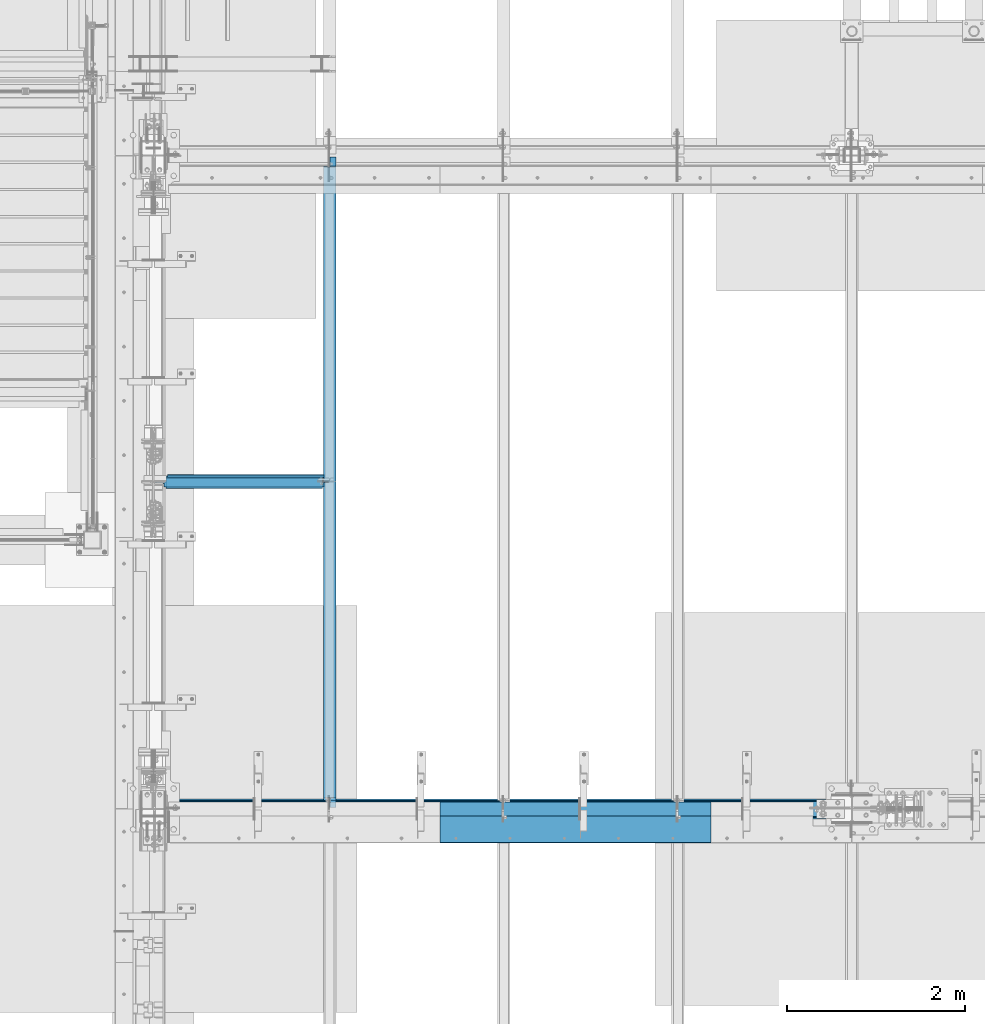
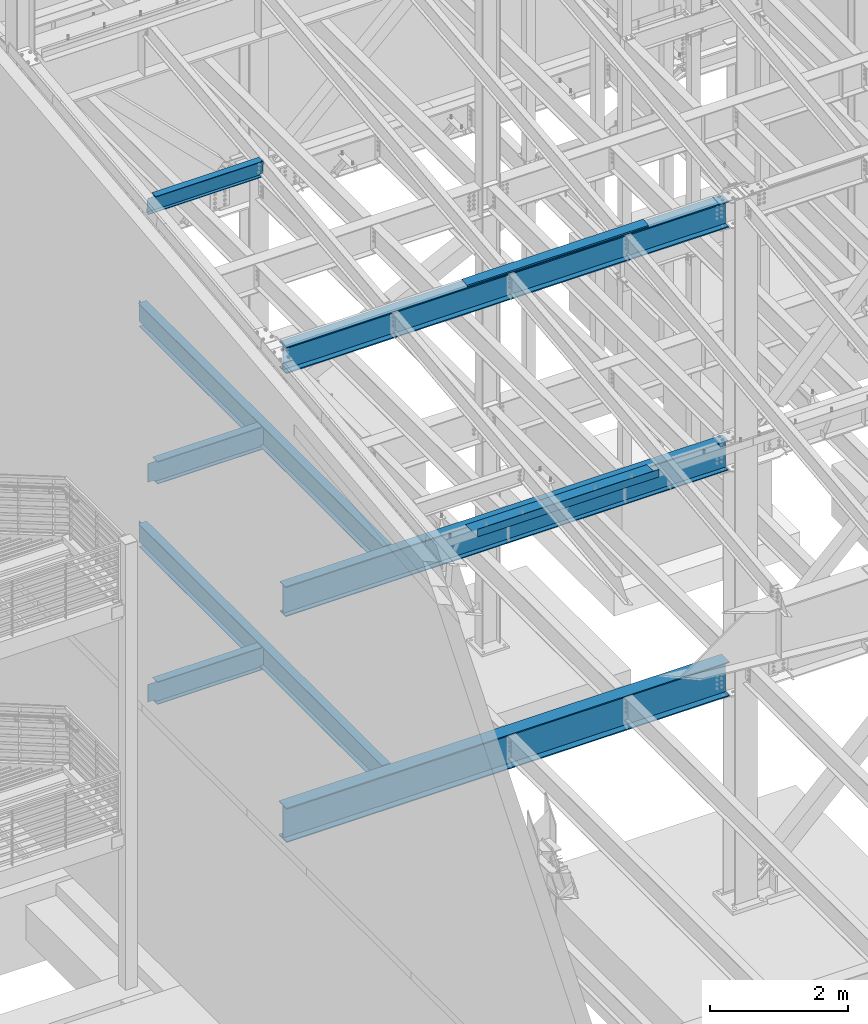
# One storey, part 731 of 1179: 10 beams, 8 elements without a shape of their own.
"""IFC2X3 building model written with IfcOpenShell, lengths in millimetres."""

from ifc_helpers import new_model, si_unit, frame, origin_with_axes, place, context, subcontext, project, spatial, faceted_brep, material, type_object, element, aggregate, save


model = new_model("IFC2X3")

# Units and contexts
model_context = context("Model", 3, precision=1e-05, world=origin_with_axes())
body_context = subcontext(model_context, "Body", "Model", "MODEL_VIEW")
ifc_project = project(units=[si_unit("LENGTHUNIT", "METRE", prefix="MILLI"), si_unit("AREAUNIT", "SQUARE_METRE"), si_unit("VOLUMEUNIT", "CUBIC_METRE"), si_unit("MASSUNIT", "GRAM", prefix="KILO"), si_unit("TIMEUNIT", "SECOND"), si_unit("PLANEANGLEUNIT", "RADIAN"), si_unit("SOLIDANGLEUNIT", "STERADIAN"), si_unit("THERMODYNAMICTEMPERATUREUNIT", "DEGREE_CELSIUS"), si_unit("LUMINOUSINTENSITYUNIT", "LUMEN")], contexts=[model_context])

# Site, building, storey
site_placement = place(None, origin_with_axes())
site = spatial("IfcSite", under=ifc_project, at=site_placement, CompositionType="ELEMENT")
building_placement = place(site_placement, origin_with_axes())
building = spatial("IfcBuilding", under=site, at=building_placement, Name="Undefined", CompositionType="ELEMENT")
storey_placement = place(building_placement, origin_with_axes())
storey = spatial("IfcBuildingStorey", under=building, at=storey_placement, Name="Undefined", CompositionType="ELEMENT", Elevation=0.0)

# Assembly, beam
assembly_1_placement = place(storey_placement, origin_with_axes())
assembly_1 = element("IfcElementAssembly", 1, at=assembly_1_placement, inside=storey, Name="BEAM", AssemblyPlace="NOTDEFINED", PredefinedType="RIGID_FRAME")
ifc_material_1 = material(Name="STEEL/A36")
beam_type_1 = type_object("IfcBeamType", PredefinedType="NOTDEFINED")
beam_1_placement = place(assembly_1_placement, frame((5173.66249999742, 27124.025, 12269.3906249899), z_axis=(-1.0, 0.0, 0.0), x_axis=(0.0, 0.0, 1.0)))
beam_1 = element("IfcBeam", 2, at=beam_1_placement, type_object=beam_type_1, material=ifc_material_1, Name="BENT_PLATE", context=body_context, shape_type="Brep", body=[
    faceted_brep([(-2.91038304567337e-11, -4.76250000000073, -1524.0), (-2.91038304567337e-11, -4.76250000000073, 1524.0), (2.91038304567337e-11, 4.76250000000073, 1524.0), (2.91038304567337e-11, 4.76250000000073, -1524.0), (43.0065173285329, 4.76249999974607, 1524.0), (43.0065173285329, 4.76249999974607, -1524.0), (32.344586885798, -4.7625000001899, -1524.0), (32.344586885798, -4.7625000001899, 1524.0), (25.4267482213236, -150.812499999749, 1524.0), (25.4267482213236, -150.812499999749, -1524.0), (16.9174425672263, -141.287499999748, -1524.0), (16.9174425672263, -141.287499999748, 1524.0), (8.54161044117063e-08, -150.812499999749, 1524.0), (8.54161044117063e-08, -150.812499999749, -1524.0), (8.54161044117063e-08, -141.287499999748, 1524.0), (8.54161044117063e-08, -141.287499999748, -1524.0)], [[[0, 1, 2, 3]], [[3, 2, 4, 5]], [[1, 0, 6, 7]], [[5, 4, 8, 9]], [[7, 6, 10, 11]], [[9, 8, 12, 13]], [[8, 4, 2, 1, 7, 11, 14, 12]], [[11, 10, 15, 14]], [[10, 6, 0, 3, 5, 9, 13, 15]], [[14, 15, 13, 12]]]),
])

assembly_2_placement = place(storey_placement, origin_with_axes())
assembly_2 = element("IfcElementAssembly", 3, at=assembly_2_placement, inside=storey, Name="BEAM", AssemblyPlace="NOTDEFINED", PredefinedType="RIGID_FRAME")
ifc_material_2 = material(Name="STEEL/A992")
beam_type_2 = type_object("IfcBeamType", Name="W16X31", PredefinedType="NOTDEFINED")
beam_2_placement = place(assembly_2_placement, frame((431.800000000001, 30721.3, 7812.0875), z_axis=(0.0, 0.0, 1.0), x_axis=(1.0, 0.0, 0.0)))
beam_2 = element("IfcBeam", 4, at=beam_2_placement, type_object=beam_type_2, material=ifc_material_2, Name="BEAM", ObjectType="W16X31", context=body_context, shape_type="Brep", body=[
    faceted_brep([(1898.65, -3.17499999999927, -190.5), (1898.65, -69.8499999999985, -190.5), (1898.65, -69.8499999999985, -201.6125), (1898.65, 69.8499999999985, -201.6125), (1898.65, 69.8499999999985, -190.5), (1898.65, 3.17499999999927, -190.5), (1898.65, 3.17499999999927, -182.562499809265), (1898.65, -3.17499999999927, -182.562499809265), (1899.61672992259, 3.17499999999927, -177.70242029122), (1899.61672992259, -3.17499999999927, -177.70242029122), (1902.36974382306, 3.17499999999927, -173.582243823066), (1902.36974382306, -3.17499999999927, -173.582243823066), (1906.48992029122, 3.17499999999927, -170.829229922588), (1906.48992029122, -3.17499999999927, -170.829229922588), (1911.34999980926, 3.17499999999927, -169.8625), (1911.34999980926, -3.17499999999927, -169.8625), (1965.325, -3.17499999999927, -169.8625), (1965.325, 3.17499999999927, -169.8625), (142.081250000001, 3.17499999999927, 190.5), (142.081250000001, 69.8499999999985, 190.5), (1898.65, 69.8499999999985, 190.5), (1898.65, 3.17499999999927, 190.5), (142.081250000001, -3.17499999999927, -179.387499809265), (142.081250000001, 3.17499999999927, -179.387499809265), (142.081250000001, 3.17499999999927, -190.5), (142.081250000001, 69.8499999999985, -190.5), (142.081250000001, 69.8499999999985, -201.6125), (142.081250000001, -69.8499999999985, -201.6125), (142.081250000001, -69.8499999999985, -190.5), (142.081250000001, -3.17499999999927, -190.5), (141.114520077413, -3.17499999999927, -174.52742029122), (141.114520077413, 3.17499999999927, -174.52742029122), (138.361506176935, -3.17499999999927, -170.407243823066), (138.361506176935, 3.17499999999927, -170.407243823066), (134.241329708781, -3.17499999999927, -167.654229922588), (134.241329708781, 3.17499999999927, -167.654229922588), (129.381250190735, -3.17499999999927, -166.6875), (129.381250190735, 3.17499999999927, -166.6875), (18.2562500000006, -3.17499999999927, -166.6875), (18.2562500000006, 3.17499999999927, -166.6875), (18.2562500000006, -3.17499999999927, 166.6875), (18.2562500000006, 3.17499999999927, 166.6875), (129.381250190735, -3.17499999999927, 166.6875), (129.381250190735, 3.17499999999927, 166.6875), (134.241329708781, -3.17499999999927, 167.654229922588), (134.241329708781, 3.17499999999927, 167.654229922588), (138.361506176935, -3.17499999999927, 170.407243823066), (138.361506176935, 3.17499999999927, 170.407243823066), (141.114520077413, -3.17499999999927, 174.52742029122), (141.114520077413, 3.17499999999927, 174.52742029122), (142.081250000001, -3.17499999999927, 179.387499809265), (142.081250000001, 3.17499999999927, 179.387499809265), (142.081250000001, -69.8499999999985, 201.6125), (142.081250000001, 69.8499999999985, 201.6125), (142.081250000001, -3.17499999999927, 190.5), (142.081250000001, -69.8499999999985, 190.5), (1898.65, -3.17499999999927, 190.5), (1898.65, -69.8499999999985, 190.5), (1898.65, -69.8499999999985, 201.6125), (1898.65, 69.8499999999985, 201.6125), (1898.65, -3.17499999999927, 182.562499809265), (1898.65, 3.17499999999927, 182.562499809265), (1899.61672992259, -3.17499999999927, 177.70242029122), (1899.61672992259, 3.17499999999927, 177.70242029122), (1902.36974382306, -3.17499999999927, 173.582243823066), (1902.36974382306, 3.17499999999927, 173.582243823066), (1906.48992029122, -3.17499999999927, 170.829229922588), (1906.48992029122, 3.17499999999927, 170.829229922588), (1911.34999980926, -3.17499999999927, 169.8625), (1911.34999980926, 3.17499999999927, 169.8625), (1965.325, -3.17499999999927, 169.8625), (1965.325, 3.17499999999927, 169.8625)], [[[0, 1, 2, 3, 4, 5, 6, 7]], [[7, 6, 8, 9]], [[9, 8, 10, 11]], [[11, 10, 12, 13]], [[13, 12, 14, 15]], [[16, 15, 14, 17]], [[18, 19, 20, 21]], [[22, 23, 24, 25, 26, 27, 28, 29]], [[30, 31, 23, 22]], [[32, 33, 31, 30]], [[34, 35, 33, 32]], [[36, 37, 35, 34]], [[38, 39, 37, 36]], [[40, 41, 39, 38]], [[42, 43, 41, 40]], [[44, 45, 43, 42]], [[46, 47, 45, 44]], [[48, 49, 47, 46]], [[50, 51, 49, 48]], [[52, 53, 19, 18, 51, 50, 54, 55]], [[55, 54, 56, 57]], [[52, 55, 57, 58]], [[53, 52, 58, 59]], [[19, 53, 59, 20]], [[58, 57, 56, 60, 61, 21, 20, 59]], [[62, 63, 61, 60]], [[64, 65, 63, 62]], [[66, 67, 65, 64]], [[68, 69, 67, 66]], [[70, 71, 69, 68]], [[71, 70, 16, 17]], [[12, 10, 8, 6, 5, 24, 23, 31, 33, 35, 37, 39, 41, 43, 45, 47, 49, 51, 18, 21, 61, 63, 65, 67, 69, 71, 17, 14]], [[25, 24, 5, 4]], [[26, 25, 4, 3]], [[27, 26, 3, 2]], [[28, 27, 2, 1]], [[29, 28, 1, 0]], [[70, 68, 66, 64, 62, 60, 56, 54, 50, 48, 46, 44, 42, 40, 38, 36, 34, 32, 30, 22, 29, 0, 7, 9, 11, 13, 15, 16]]]),
])
aggregate(assembly_2, [beam_2])

assembly_3_placement = place(storey_placement, origin_with_axes())
assembly_3 = element("IfcElementAssembly", 5, at=assembly_3_placement, inside=storey, Name="BEAM", AssemblyPlace="NOTDEFINED", PredefinedType="RIGID_FRAME")
beam_3_placement = place(assembly_3_placement, frame((2413.0, 27051.0, 7812.0875), z_axis=(0.0, 0.0, 1.0), x_axis=(0.0, 1.0, 0.0)))
beam_3 = element("IfcBeam", 6, at=beam_3_placement, type_object=beam_type_2, material=ifc_material_2, Name="BEAM", ObjectType="W16X31", context=body_context, shape_type="Brep", body=[
    faceted_brep([(82.5499999999993, -3.17500000000291, 166.6875), (82.5499999999993, 3.17500000000291, 166.6875), (17.4624999999942, 3.17499999999927, 166.6875), (17.4624999999942, -3.17499999999927, 166.6875), (87.4100797087813, -3.17499999999927, 167.654229922588), (87.4100797087813, 3.17497144083973, 167.654229922588), (91.5302561769349, -3.17499999999927, 170.407243823066), (91.5302561769349, 3.17496966460385, 170.407243823066), (94.2832700774125, -3.17499999999927, 174.52742029122), (94.2832700774125, 3.1749670062818, 174.52742029122), (95.25, -3.17499999999927, 179.387499809265), (95.25, 3.1749638705769, 179.387499809265), (95.25, -69.8499999999985, 201.6125), (95.25, 69.8499999999985, 201.6125), (95.25, 69.8499999999985, 190.5), (95.25, 3.17499999999927, 190.5), (95.25, -3.17499999999927, 190.5), (95.25, -69.8499999999985, 190.5), (7196.1375, 3.17499999999927, -190.5), (7196.1375, 69.8500000000004, -190.5), (144.462499999994, 69.8499999999985, -190.5), (144.462499999994, 3.17549991607666, -190.5), (17.4624999999942, -3.17499999999927, -190.5), (17.4624999999942, -69.8499999999985, -190.5), (7323.1375, -69.8500000000004, -190.5), (7323.1375, -3.17499999999927, -190.5), (17.4624999999942, -69.8499999999985, -201.6125), (7323.1375, -69.8500000000004, -201.6125), (7196.1375, 69.8500000000004, -201.6125), (7196.1375, 3.17549991607484, -201.6125), (7323.1375, 3.17549991607484, -201.6125), (17.4624999999942, 3.17549991607666, -201.6125), (144.462499999994, 3.17549991607666, -201.6125), (144.462499999994, 69.8499999999985, -201.6125), (17.4624999999942, 3.17499999999927, -190.5), (7323.1375, 3.17499999999927, -190.5), (7323.1375, 3.17499999999927, 166.6875), (7323.1375, -3.17499999999927, 166.6875), (7235.82499980928, 3.17499999999927, 166.6875), (7235.82499980928, -3.17499999999927, 166.6875), (7230.96492029123, 3.17499999999927, 167.654229922588), (7230.96492029123, -3.17499999999927, 167.654229922588), (7226.84474382308, 3.17499999999927, 170.407243823066), (7226.84474382308, -3.17499999999927, 170.407243823066), (7224.0917299226, 3.17499999999927, 174.52742029122), (7224.0917299226, -3.17499999999927, 174.52742029122), (7223.12500000001, 3.17499999999927, 179.387499809265), (7223.12500000001, -3.17499999999927, 179.387499809265), (7223.12500000001, -69.8500000000004, 201.6125), (7223.12500000001, -69.8500000000004, 190.5), (7223.12500000001, -3.17499999999927, 190.5), (7223.12500000001, 3.17499999999927, 190.5), (7223.12500000001, 69.8500000000004, 190.5), (7223.12500000001, 69.8500000000004, 201.6125)], [[[0, 1, 2, 3]], [[4, 5, 1, 0]], [[6, 7, 5, 4]], [[8, 9, 7, 6]], [[10, 11, 9, 8]], [[12, 13, 14, 15, 11, 10, 16, 17]], [[18, 19, 20, 21]], [[22, 23, 24, 25]], [[23, 26, 27, 24]], [[28, 29, 30, 27, 26, 31, 32, 33]], [[21, 32, 31, 34]], [[20, 33, 32, 21]], [[19, 28, 33, 20]], [[18, 29, 28, 19]], [[35, 30, 29, 18]], [[25, 24, 27, 30, 35, 36, 37]], [[37, 36, 38, 39]], [[39, 38, 40, 41]], [[41, 40, 42, 43]], [[43, 42, 44, 45]], [[45, 44, 46, 47]], [[48, 49, 50, 47, 46, 51, 52, 53]], [[49, 48, 12, 17]], [[50, 49, 17, 16]], [[8, 6, 4, 0, 3, 22, 25, 37, 39, 41, 43, 45, 47, 50, 16, 10]], [[34, 31, 26, 23, 22, 3, 2]], [[51, 46, 44, 42, 40, 38, 36, 35, 18, 21, 34, 2, 1, 5, 7, 9, 11, 15]], [[52, 51, 15, 14]], [[53, 52, 14, 13]], [[48, 53, 13, 12]]]),
])
aggregate(assembly_3, [beam_3])

assembly_4_placement = place(storey_placement, origin_with_axes())
assembly_4 = element("IfcElementAssembly", 7, at=assembly_4_placement, inside=storey, Name="BEAM", AssemblyPlace="NOTDEFINED", PredefinedType="RIGID_FRAME")
beam_4_placement = place(assembly_4_placement, frame((431.800000000002, 30721.3, 3900.4875), z_axis=(0.0, 0.0, 1.0), x_axis=(1.0, 0.0, 0.0)))
beam_4 = element("IfcBeam", 8, at=beam_4_placement, type_object=beam_type_2, material=ifc_material_2, Name="BEAM", ObjectType="W16X31", context=body_context, shape_type="Brep", body=[
    faceted_brep([(1898.64985351562, -3.17499999999927, -190.5), (1898.64985351562, -69.8500000000004, -190.5), (1898.64985351562, -69.8500000000004, -201.6125), (1898.64985351562, 69.8500000000004, -201.6125), (1898.64985351562, 69.8500000000004, -190.5), (1898.64985351562, 3.17499999999927, -190.5), (1898.64985351562, 3.17499999999927, -182.562499809264), (1898.64985351562, -3.17499999999927, -182.562499809264), (1899.61658343821, 3.17499999999927, -177.702420291219), (1899.61658343821, -3.17499999999927, -177.702420291219), (1902.36959733869, 3.17499999999927, -173.582243823065), (1902.36959733869, -3.17499999999927, -173.582243823065), (1906.48977380684, 3.17499999999927, -170.829229922587), (1906.48977380684, -3.17499999999927, -170.829229922587), (1911.34985332489, 3.17499999999927, -169.862499999999), (1911.34985332489, -3.17499999999927, -169.862499999999), (1965.32485351562, -3.17499999999927, -169.862499999999), (1965.32485351562, 3.17499999999927, -169.862499999999), (142.081250000001, 3.17499999999927, 190.5), (142.081250000001, 69.8499999999985, 190.5), (1898.64985351562, 69.8500000000004, 190.5), (1898.64985351562, 3.17499999999927, 190.5), (142.08125, -3.17499999999927, -169.862499809266), (142.08125, 3.17499999999927, -169.862499809266), (142.081250000001, 3.17499999999927, -190.5), (142.081250000001, 69.8499999999985, -190.5), (142.081250000001, 69.8499999999985, -201.6125), (142.081250000001, -69.8499999999985, -201.6125), (142.081250000001, -69.8499999999985, -190.5), (142.081250000001, -3.17499999999927, -190.5), (141.114520077412, -3.17499999999927, -165.00242029122), (141.114520077412, 3.17499999999927, -165.00242029122), (138.361506176934, -3.17499999999927, -160.882243823066), (138.361506176934, 3.17499999999927, -160.882243823066), (134.24132970878, -3.17499999999927, -158.129229922588), (134.24132970878, 3.17499999999927, -158.129229922588), (129.381250190735, -3.17499999999927, -157.1625), (129.381250190735, 3.17499999999927, -157.1625), (18.2562499999996, -3.17499999999927, -157.1625), (18.2562499999996, 3.17499999999927, -157.1625), (18.2562499999996, -3.17499999999927, 157.1625), (18.2562499999996, 3.17499999999927, 157.1625), (129.381250190735, -3.17499999999927, 157.1625), (129.381250190735, 3.17499999999927, 157.1625), (134.24132970878, -3.17499999999927, 158.129229922588), (134.24132970878, 3.17499999999927, 158.129229922588), (138.361506176934, -3.17499999999927, 160.882243823066), (138.361506176934, 3.17499999999927, 160.882243823066), (141.114520077412, -3.17499999999927, 165.00242029122), (141.114520077412, 3.17499999999927, 165.00242029122), (142.08125, -3.17499999999927, 169.862499809265), (142.08125, 3.17499999999927, 169.862499809265), (142.081250000001, -69.8499999999985, 201.6125), (142.081250000001, 69.8499999999985, 201.6125), (142.081250000001, -3.17499999999927, 190.5), (142.081250000001, -69.8499999999985, 190.5), (1898.64985351562, -3.17499999999927, 190.5), (1898.64985351562, -69.8500000000004, 190.5), (1898.64985351562, -69.8500000000004, 201.6125), (1898.64985351562, 69.8500000000004, 201.6125), (1898.64985351562, -3.17499999999927, 182.562499809266), (1898.64985351562, 3.17499999999927, 182.562499809266), (1899.61658343821, -3.17499999999927, 177.70242029122), (1899.61658343821, 3.17499999999927, 177.70242029122), (1902.36959733869, -3.17499999999927, 173.582243823067), (1902.36959733869, 3.17499999999927, 173.582243823067), (1906.48977380684, -3.17499999999927, 170.829229922589), (1906.48977380684, 3.17499999999927, 170.829229922589), (1911.34985332489, -3.17499999999927, 169.862500000001), (1911.34985332489, 3.17499999999927, 169.862500000001), (1965.32485351562, -3.17499999999927, 169.862500000001), (1965.32485351562, 3.17499999999927, 169.862500000001)], [[[0, 1, 2, 3, 4, 5, 6, 7]], [[7, 6, 8, 9]], [[9, 8, 10, 11]], [[11, 10, 12, 13]], [[13, 12, 14, 15]], [[16, 15, 14, 17]], [[18, 19, 20, 21]], [[22, 23, 24, 25, 26, 27, 28, 29]], [[30, 31, 23, 22]], [[32, 33, 31, 30]], [[34, 35, 33, 32]], [[36, 37, 35, 34]], [[38, 39, 37, 36]], [[40, 41, 39, 38]], [[42, 43, 41, 40]], [[44, 45, 43, 42]], [[46, 47, 45, 44]], [[48, 49, 47, 46]], [[50, 51, 49, 48]], [[52, 53, 19, 18, 51, 50, 54, 55]], [[55, 54, 56, 57]], [[52, 55, 57, 58]], [[53, 52, 58, 59]], [[19, 53, 59, 20]], [[58, 57, 56, 60, 61, 21, 20, 59]], [[62, 63, 61, 60]], [[64, 65, 63, 62]], [[66, 67, 65, 64]], [[68, 69, 67, 66]], [[70, 71, 69, 68]], [[71, 70, 16, 17]], [[12, 10, 8, 6, 5, 24, 23, 31, 33, 35, 37, 39, 41, 43, 45, 47, 49, 51, 18, 21, 61, 63, 65, 67, 69, 71, 17, 14]], [[25, 24, 5, 4]], [[26, 25, 4, 3]], [[27, 26, 3, 2]], [[28, 27, 2, 1]], [[29, 28, 1, 0]], [[70, 68, 66, 64, 62, 60, 56, 54, 50, 48, 46, 44, 42, 40, 38, 36, 34, 32, 30, 22, 29, 0, 7, 9, 11, 13, 15, 16]]]),
])
aggregate(assembly_4, [beam_4])

assembly_5_placement = place(storey_placement, origin_with_axes())
assembly_5 = element("IfcElementAssembly", 9, at=assembly_5_placement, inside=storey, Name="BEAM", AssemblyPlace="NOTDEFINED", PredefinedType="RIGID_FRAME")
beam_5_placement = place(assembly_5_placement, frame((2412.99985351563, 27051.0, 3900.4875), z_axis=(0.0, 0.0, 1.0), x_axis=(0.0, 1.0, 0.0)))
beam_5 = element("IfcBeam", 10, at=beam_5_placement, type_object=beam_type_2, material=ifc_material_2, Name="BEAM", ObjectType="W16X31", context=body_context, shape_type="Brep", body=[
    faceted_brep([(114.300000190742, -3.17499999999927, 169.8625), (114.300000190742, 3.17497080806788, 169.8625), (19.0500000762049, 3.17499999999382, 169.8625), (19.0499999238054, -3.17500000000564, 169.8625), (119.160079708789, -3.17499999999927, 170.829229922588), (119.160079708789, 3.17497018437643, 170.829229922588), (123.280256176942, -3.17499999999927, 173.582243823066), (123.280256176942, 3.1749684082497, 173.582243823066), (126.03327007742, -3.17499999999927, 177.70242029122), (126.03327007742, 3.17496575008772, 177.70242029122), (127.000000000007, -3.17499999999927, 182.562499809265), (127.000000000007, 3.174962614572, 182.562499809265), (127.000000000007, -69.8499999999985, 201.6125), (127.000000000007, 69.8499999999985, 201.6125), (127.000000000007, 69.8499999999985, 190.5), (127.000000000007, 3.17499999999927, 190.5), (127.000000000007, -3.17499999999927, 190.5), (127.000000000007, -69.8499999999985, 190.5), (7195.34375, 3.17499999999927, -190.5), (7195.34375, 69.8499999999985, -190.5), (146.049999999996, 69.8499999999985, -190.5), (146.049999999996, 3.17549991607666, -190.5), (19.0499999999993, -3.17499999999927, -190.5), (19.0499999999993, -69.8499999999985, -190.5), (7322.34375, -69.8499999999985, -190.5), (7322.34375, -3.17499999999927, -190.5), (19.0499999999993, -69.8499999999985, -201.6125), (7322.34375, -69.8499999999985, -201.6125), (7195.34375, 69.8499999999985, -201.6125), (7195.34375, 3.17561706324705, -201.6125), (7322.34375, 3.17561706324705, -201.6125), (19.0499999999993, 3.17549991607666, -201.6125), (146.049999999996, 3.17549991607666, -201.6125), (146.049999999996, 69.8499999999985, -201.6125), (19.0499999999993, 3.17499999999927, -190.5), (7322.34375, 3.17499999999927, -190.5), (7322.34375, 3.17499999999927, 169.8625), (7322.34375, -3.17499999999927, 169.8625), (7227.09374980925, 3.17499999999927, 169.8625), (7227.09374980925, -3.17499999999927, 169.8625), (7222.2336702912, 3.17499999999927, 170.829229922588), (7222.2336702912, -3.17499999999927, 170.829229922588), (7218.11349382305, 3.17499999999927, 173.582243823066), (7218.11349382305, -3.17499999999927, 173.582243823066), (7215.36047992257, 3.17499999999927, 177.70242029122), (7215.36047992257, -3.17499999999927, 177.70242029122), (7214.39374999998, 3.17499999999927, 182.562499809265), (7214.39374999998, -3.17499999999927, 182.562499809265), (7214.39374999998, -69.8499999999985, 201.6125), (7214.39374999998, -69.8499999999985, 190.5), (7214.39374999998, -3.17499999999927, 190.5), (7214.39374999998, 3.17499999999927, 190.5), (7214.39374999998, 69.8499999999985, 190.5), (7214.39374999998, 69.8499999999985, 201.6125)], [[[0, 1, 2, 3]], [[4, 5, 1, 0]], [[6, 7, 5, 4]], [[8, 9, 7, 6]], [[10, 11, 9, 8]], [[12, 13, 14, 15, 11, 10, 16, 17]], [[18, 19, 20, 21]], [[22, 23, 24, 25]], [[23, 26, 27, 24]], [[28, 29, 30, 27, 26, 31, 32, 33]], [[21, 32, 31, 34]], [[20, 33, 32, 21]], [[19, 28, 33, 20]], [[18, 29, 28, 19]], [[35, 30, 29, 18]], [[25, 24, 27, 30, 35, 36, 37]], [[37, 36, 38, 39]], [[39, 38, 40, 41]], [[41, 40, 42, 43]], [[43, 42, 44, 45]], [[45, 44, 46, 47]], [[48, 49, 50, 47, 46, 51, 52, 53]], [[49, 48, 12, 17]], [[50, 49, 17, 16]], [[8, 6, 4, 0, 3, 22, 25, 37, 39, 41, 43, 45, 47, 50, 16, 10]], [[34, 31, 26, 23, 22, 3, 2]], [[51, 46, 44, 42, 40, 38, 36, 35, 18, 21, 34, 2, 1, 5, 7, 9, 11, 15]], [[52, 51, 15, 14]], [[53, 52, 14, 13]], [[48, 53, 13, 12]]]),
])
aggregate(assembly_5, [beam_5])

assembly_6_placement = place(storey_placement, origin_with_axes())
assembly_6 = element("IfcElementAssembly", 11, at=assembly_6_placement, inside=storey, Name="BEAM", AssemblyPlace="NOTDEFINED", PredefinedType="RIGID_FRAME")
beam_type_3 = type_object("IfcBeamType", PredefinedType="NOTDEFINED")
beam_6_placement = place(assembly_6_placement, frame((5173.66246123733, 26673.175, 8147.05000610352), z_axis=(1.0, 0.0, 0.0), x_axis=(0.0, 0.0, -1.0)))
beam_6 = element("IfcBeam", 12, at=beam_6_placement, type_object=beam_type_3, material=ifc_material_1, Name="BENT_PLATE", context=body_context, shape_type="Brep", body=[
    faceted_brep([(0.0, -3.17499999999927, -1524.0), (6.00266503170133e-10, -3.17499999922438, 1524.00000000052), (6.00266503170133e-10, 3.17500000077416, 1524.00000000052), (0.0, 3.17499999999927, -1524.0), (127.000006103516, 3.17499999999927, 1524.0), (127.000006103516, 3.17499999999927, -1524.0), (133.350006103517, -3.17499999999927, -1524.0), (133.350006103517, -3.17499999999927, 1524.0), (127.000006103516, 346.074999237058, 1524.0), (127.000006103516, 346.074999237058, -1524.0), (133.350006103517, 346.074999237058, 1524.0), (133.350006103517, 346.074999237058, -1524.0)], [[[0, 1, 2, 3]], [[3, 2, 4, 5]], [[1, 0, 6, 7]], [[5, 4, 8, 9]], [[4, 2, 1, 7, 10, 8]], [[7, 6, 11, 10]], [[6, 0, 3, 5, 9, 11]], [[10, 11, 9, 8]]]),
])

# Beam
beam_type_4 = type_object("IfcBeamType", Name="W18X65", PredefinedType="NOTDEFINED")
beam_7_placement = place(assembly_1_placement, frame((431.800000000001, 27050.9999999701, 12036.0281250357), z_axis=(0.0, 0.0, 1.0), x_axis=(1.0, 0.0, 0.0)))
beam_7 = element("IfcBeam", 13, at=beam_7_placement, type_object=beam_type_4, material=ifc_material_2, Name="BEAM", ObjectType="W18X65", context=body_context, shape_type="Brep", body=[
    faceted_brep([(169.8625, -96.8375000000015, -233.362499999999), (169.8625, 96.8375000000015, -233.362499999999), (7600.95, 96.8375000000015, -233.362499999999), (7600.95, -96.8375000000015, -233.362499999999), (169.8625, -96.8375000000015, -214.3125), (169.8625, -5.55625000000146, -214.3125), (169.8625, -5.55625000000146, 214.3125), (169.8625, -96.8375000000015, 214.3125), (169.8625, -96.8375000000015, 233.362499999999), (169.8625, 96.8375000000015, 233.362499999999), (169.8625, 96.8375000000015, 214.3125), (169.8625, 5.55625000000146, 214.3125), (169.8625, 5.55625000000146, -214.3125), (169.8625, 96.8375000000015, -214.3125), (7600.95, -96.8375000000015, -214.3125), (7600.95, -5.55625000000146, -214.3125), (7600.95, -5.55625000000146, 214.3125), (7600.95, -96.8375000000015, 214.3125), (7600.95, -96.8375000000015, 233.362499999999), (7600.95, 96.8375000000015, 233.362499999999), (7600.95, 96.8375000000015, 214.3125), (7600.95, 5.55625000000146, 214.3125), (7600.95, 5.55625000000146, 196.00250000013), (7600.95, 5.55625000000146, -110.277499999973), (7600.95, 5.55625000000146, -214.3125), (7600.95, 96.8375000000015, -214.3125)], [[[0, 1, 2, 3]], [[0, 4, 5, 6, 7, 8, 9, 10, 11, 12, 13, 1]], [[5, 4, 14, 15]], [[6, 5, 15, 16]], [[7, 6, 16, 17]], [[8, 7, 17, 18]], [[9, 8, 18, 19]], [[10, 9, 19, 20]], [[11, 10, 20, 21]], [[12, 11, 21, 22, 23, 24]], [[13, 12, 24, 25]], [[1, 13, 25, 2]], [[24, 23, 22, 21, 20, 19, 18, 17, 16, 15, 14, 3, 2, 25]], [[4, 0, 3, 14]]]),
])

aggregate(assembly_1, [beam_1, beam_7])

# Assembly, beam
assembly_7_placement = place(storey_placement, origin_with_axes())
assembly_7 = element("IfcElementAssembly", 14, at=assembly_7_placement, inside=storey, Name="BEAM", AssemblyPlace="NOTDEFINED", PredefinedType="RIGID_FRAME")
beam_type_5 = type_object("IfcBeamType", Name="W12X22", PredefinedType="NOTDEFINED")
beam_8_placement = place(assembly_7_placement, frame((431.800000000002, 30738.7779321232, 12563.7561799803), z_axis=(0.0, -0.112284087038017, 0.993676146336441), x_axis=(1.0, 0.0, 0.0)))
beam_8 = element("IfcBeam", 15, at=beam_8_placement, type_object=beam_type_5, material=ifc_material_2, Name="BEAM", ObjectType="W12X22", context=body_context, shape_type="Brep", body=[
    faceted_brep([(1917.7, -3.1750000000502, -144.462499999914), (1917.7, -50.8000000000247, -144.462499999896), (1917.7, -50.8000000000284, -155.574999999892), (1917.7, 50.7999999999156, -155.574999999932), (1917.7, 50.7999999999192, -144.46249999994), (1917.7, 3.17499999869324, -144.462499999918), (1917.7, 3.17499998151106, -142.874999810523), (1917.7, -3.17500000004657, -142.874999810521), (1918.66672992259, 3.17499998191852, -138.014920292486), (1918.66672992259, -3.17500000004657, -138.014920292482), (1921.41974382307, 3.17499998226413, -133.894743824339), (1921.41974382307, -3.17500000004293, -133.894743824334), (1925.53992029122, 3.17499998249332, -131.141729923864), (1925.53992029122, -3.17500000004293, -131.141729923862), (1930.39999980926, 3.17499998257699, -130.175000001278), (1930.39999980926, -3.17500000004293, -130.175000001276), (1965.325, -3.17500000004293, -130.175000001276), (1965.325, 3.17499999995198, -130.175000001278), (121.44375, 3.17500000006476, 144.462499999918), (121.44375, 50.8000000000357, 144.4624999999), (1917.7, 50.8000000000357, 144.4624999999), (1917.7, 3.17500000006476, 144.462499999918), (159.54375, 50.7999999999192, -144.46249999994), (159.54375, 50.7999999999156, -155.574999999932), (159.54375, 3.17499995235266, -155.574999999913), (159.54375, 3.17499995235994, -144.462499999918), (19.8437500000002, 3.17499995235266, -155.574999999913), (19.8437500000002, 3.17499999994834, -144.46249999992), (19.8437500000002, -50.8000000000284, -155.574999999892), (19.8437500000002, -50.8000000000247, -144.462499999896), (19.8437500000002, -3.1750000000502, -144.462499999914), (19.8437500000002, -3.1749999999447, 117.474999998307), (19.8437500000002, 3.17500000005384, 117.474999998303), (108.743750190735, -3.1749999999447, 117.474999998307), (108.743750190735, 3.17500000199652, 117.474999998303), (113.603829708781, -3.1749999999447, 118.441729920891), (113.603829708781, 3.17500000207292, 118.441729920887), (117.724006176934, -3.1749999999447, 121.194743821365), (117.724006176934, 3.17500000229848, 121.194743821363), (120.477020077412, -3.17499999993743, 125.314920289511), (120.477020077412, 3.17500000264045, 125.314920289509), (121.44375, -3.17499999993743, 130.174999807548), (121.44375, 3.17500000304426, 130.174999807547), (121.44375, -50.799999999901, 155.574999999935), (121.44375, 50.8000000000429, 155.574999999893), (121.44375, -3.17499999993379, 144.462499999923), (121.44375, -50.7999999999047, 144.462499999941), (1917.7, -3.17499999993379, 144.462499999923), (1917.7, -50.7999999999047, 144.462499999941), (1917.7, -50.799999999901, 155.574999999935), (1917.7, 50.8000000000429, 155.574999999893), (1917.7, -3.17499999993015, 142.874999807531), (1917.7, 3.17500000523796, 142.874999807529), (1918.66672992259, -3.17499999993379, 138.014920289494), (1918.66672992259, 3.17500000483415, 138.01492028949), (1921.41974382307, -3.17499999993743, 133.894743821347), (1921.41974382307, 3.17500000449218, 133.894743821345), (1925.53992029122, -3.17499999993379, 131.141729920873), (1925.53992029122, 3.17500000425935, 131.141729920872), (1930.39999980926, -3.17499999994106, 130.174999998288), (1930.39999980926, 3.17500000417931, 130.174999998286), (1965.325, -3.17499999994106, 130.174999998288), (1965.325, 3.17500000005748, 130.174999998284)], [[[0, 1, 2, 3, 4, 5, 6, 7]], [[7, 6, 8, 9]], [[9, 8, 10, 11]], [[11, 10, 12, 13]], [[13, 12, 14, 15]], [[16, 15, 14, 17]], [[18, 19, 20, 21]], [[22, 23, 24, 25]], [[25, 24, 26, 27]], [[27, 26, 28, 29, 30, 31, 32]], [[33, 34, 32, 31]], [[35, 36, 34, 33]], [[37, 38, 36, 35]], [[39, 40, 38, 37]], [[41, 42, 40, 39]], [[43, 44, 19, 18, 42, 41, 45, 46]], [[46, 45, 47, 48]], [[43, 46, 48, 49]], [[44, 43, 49, 50]], [[19, 44, 50, 20]], [[49, 48, 47, 51, 52, 21, 20, 50]], [[53, 54, 52, 51]], [[55, 56, 54, 53]], [[57, 58, 56, 55]], [[59, 60, 58, 57]], [[61, 62, 60, 59]], [[62, 61, 16, 17]], [[12, 10, 8, 6, 5, 25, 27, 32, 34, 36, 38, 40, 42, 18, 21, 52, 54, 56, 58, 60, 62, 17, 14]], [[22, 25, 5, 4]], [[23, 22, 4, 3]], [[28, 26, 24, 23, 3, 2]], [[29, 28, 2, 1]], [[30, 29, 1, 0]], [[61, 59, 57, 55, 53, 51, 47, 45, 41, 39, 37, 35, 33, 31, 30, 0, 7, 9, 11, 13, 15, 16]]]),
])
aggregate(assembly_7, [beam_8])

# Beam
beam_type_6 = type_object("IfcBeamType", Name="W21X57", PredefinedType="NOTDEFINED")
beam_9_placement = place(assembly_6_placement, frame((431.800000000001, 27051.0, 7747.0), z_axis=(0.0, 0.0, 1.0), x_axis=(1.0, 0.0, 0.0)))
beam_9 = element("IfcBeam", 16, at=beam_9_placement, type_object=beam_type_6, material=ifc_material_2, Name="BEAM", ObjectType="W21X57", context=body_context, shape_type="Brep", body=[
    faceted_brep([(169.8625, -82.5499999999993, -266.7), (169.8625, 82.5499999999993, -266.7), (7600.95, 82.5499999999993, -266.7), (7600.95, -82.5499999999993, -266.7), (169.8625, -82.5499999999993, -250.825), (169.8625, -4.76250000000073, -250.825), (169.8625, -4.76250000000073, 250.825), (169.8625, -82.5499999999993, 250.825), (169.8625, -82.5499999999993, 266.7), (169.8625, 82.5499999999993, 266.7), (169.8625, 82.5499999999993, 250.825), (169.8625, 4.76250000000073, 250.825), (169.8625, 4.76250000000073, -250.825), (169.8625, 82.5499999999993, -250.825), (7600.95, -82.5499999999993, -250.825), (7600.95, -4.76250000000073, -250.825), (7600.95, -4.76250000000073, 250.825), (7600.95, -82.5499999999993, 250.825), (7600.95, -82.5499999999993, 266.7), (7600.95, 82.5499999999993, 266.7), (7600.95, 82.5499999999993, 250.825), (7600.95, 4.76250000000073, 250.825), (7600.95, 4.76250000000073, 216.640000000149), (7600.95, 4.76250000000073, -165.83999999998), (7600.95, 4.76250000000073, -250.825), (7600.95, 82.5499999999993, -250.825)], [[[0, 1, 2, 3]], [[0, 4, 5, 6, 7, 8, 9, 10, 11, 12, 13, 1]], [[5, 4, 14, 15]], [[6, 5, 15, 16]], [[7, 6, 16, 17]], [[8, 7, 17, 18]], [[9, 8, 18, 19]], [[10, 9, 19, 20]], [[11, 10, 20, 21]], [[12, 11, 21, 22, 23, 24]], [[13, 12, 24, 25]], [[1, 13, 25, 2]], [[24, 23, 22, 21, 20, 19, 18, 17, 16, 15, 14, 3, 2, 25]], [[4, 0, 3, 14]]]),
])

aggregate(assembly_6, [beam_6, beam_9])

# Assembly, beam
assembly_8_placement = place(storey_placement, origin_with_axes())
assembly_8 = element("IfcElementAssembly", 17, at=assembly_8_placement, inside=storey, Name="BEAM", AssemblyPlace="NOTDEFINED", PredefinedType="RIGID_FRAME")
beam_type_7 = type_object("IfcBeamType", Name="W24X84", PredefinedType="NOTDEFINED")
beam_10_placement = place(assembly_8_placement, frame((431.800000000001, 27051.0, 3795.7125), z_axis=(0.0, 0.0, 1.0), x_axis=(1.0, 0.0, 0.0)))
beam_10 = element("IfcBeam", 18, at=beam_10_placement, type_object=beam_type_7, material=ifc_material_2, Name="BEAM", ObjectType="W24X84", context=body_context, shape_type="Brep", body=[
    faceted_brep([(169.8625, -114.299999999999, -306.3875), (169.8625, 114.299999999999, -306.3875), (7600.95, 114.299999999999, -306.3875), (7600.95, -114.299999999999, -306.3875), (169.8625, -114.299999999999, -287.3375), (169.8625, -6.34999999999854, -287.3375), (169.8625, -6.34999999999854, 287.3375), (169.8625, -114.299999999999, 287.3375), (169.8625, -114.299999999999, 306.3875), (169.8625, 114.299999999999, 306.3875), (169.8625, 114.299999999999, 287.3375), (169.8625, 6.34999999999854, 287.3375), (169.8625, 6.34999999999854, -287.3375), (169.8625, 114.299999999999, -287.3375), (7600.95, -114.299999999999, -287.3375), (7600.95, -6.34999999999854, -287.3375), (7600.95, -6.34999999999854, 287.3375), (7600.95, -114.299999999999, 287.3375), (7600.95, -114.299999999999, 306.3875), (7600.95, 114.299999999999, 306.3875), (7600.95, 114.299999999999, 287.3375), (7600.95, 6.34999999999854, 287.3375), (7600.95, 6.34999999999854, 243.6275), (7600.95, 6.34999999999854, -215.0525), (7600.95, 6.34999999999854, -287.3375), (7600.95, 114.299999999999, -287.3375)], [[[0, 1, 2, 3]], [[0, 4, 5, 6, 7, 8, 9, 10, 11, 12, 13, 1]], [[5, 4, 14, 15]], [[6, 5, 15, 16]], [[7, 6, 16, 17]], [[8, 7, 17, 18]], [[9, 8, 18, 19]], [[10, 9, 19, 20]], [[11, 10, 20, 21]], [[12, 11, 21, 22, 23, 24]], [[13, 12, 24, 25]], [[1, 13, 25, 2]], [[24, 23, 22, 21, 20, 19, 18, 17, 16, 15, 14, 3, 2, 25]], [[4, 0, 3, 14]]]),
])
aggregate(assembly_8, [beam_10])

save(model, "model.ifc")
